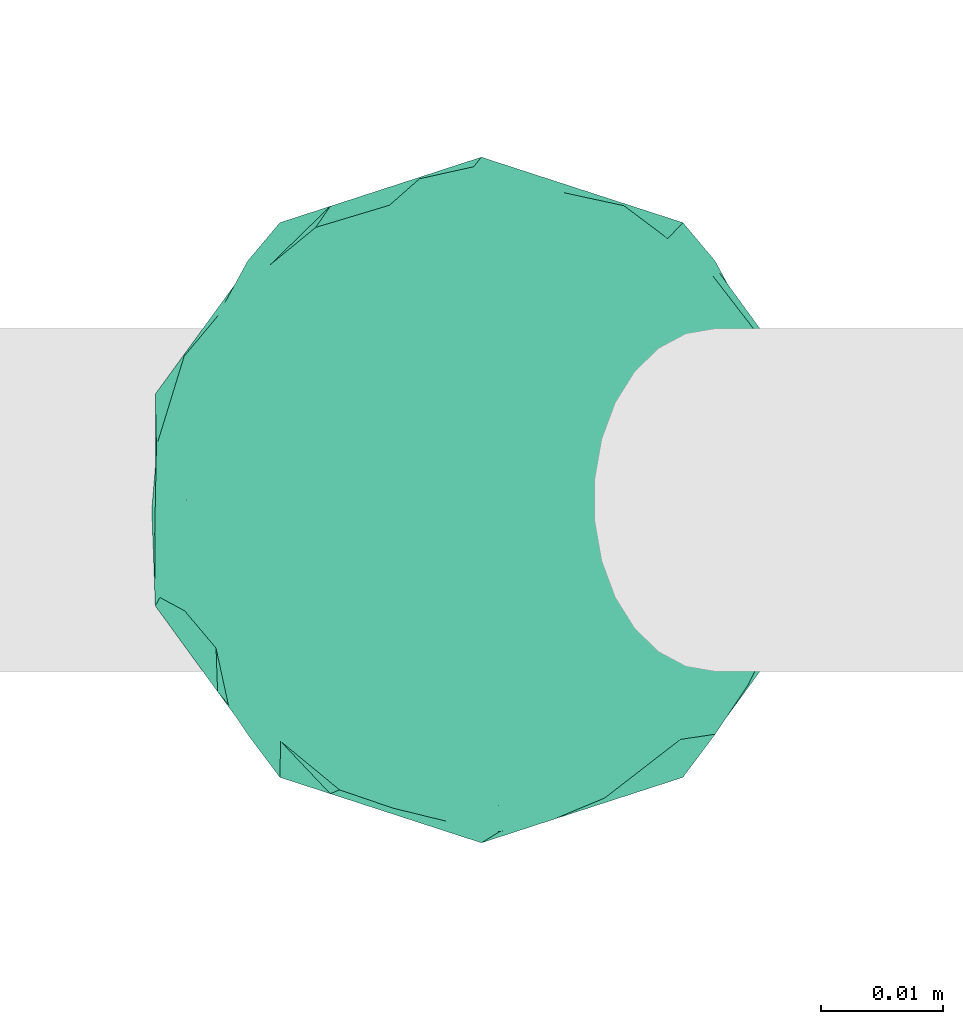
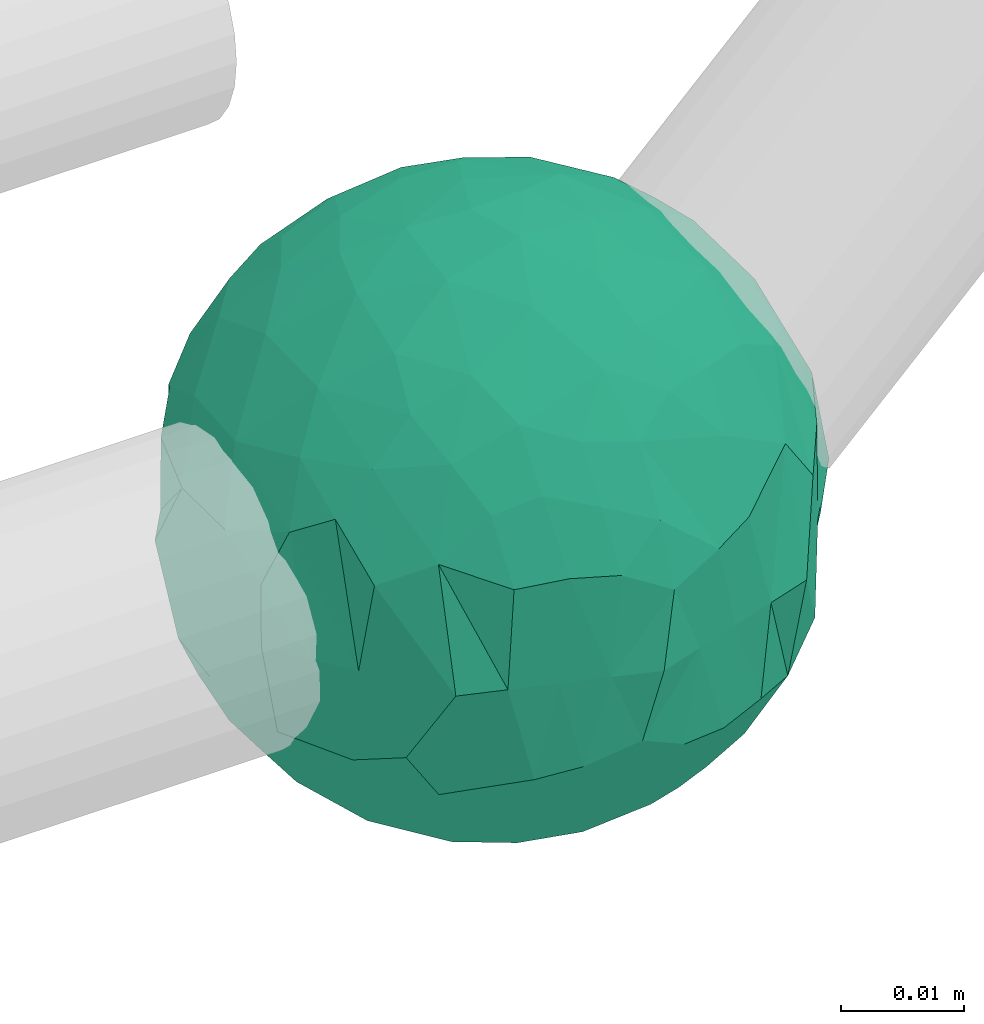
# One storey, part 324 of 331: 1 flow fitting.
"""IFC2X3 building model written with IfcOpenShell, lengths in millimetres."""

import ifcopenshell
import ifcopenshell.guid

model = None  # the IFC model being written
_history = None  # IfcOwnerHistory: only IFC2X3 demands one
_inside = {}  # id of a spatial element -> (the spatial element, [elements in it])
_under = {}  # id of a project, library or spatial element -> (it, [spatial elements below it])
_declared = {}  # id of a project -> (the project, [libraries it declares])
_typed = {}  # id of a type object -> (the type object, [elements of that type])
_made_of = {}  # id of a material, layer set ... -> (it, [elements and type objects made of it])


def new_model(schema):
    """Start an empty IFC model of exactly this schema.

    Asked for "IFC4X3", IfcOpenShell would pick the latest addendum, in which some entities
    have other attributes; the version numbers below select the first issue.
    IFC2X3 requires an IfcOwnerHistory on every rooted entity: one is made here for all.
    """
    global model, _history
    if schema == "IFC4X3":
        model = ifcopenshell.file(schema_version=(4, 3, 0, 0))
    else:
        model = ifcopenshell.file(schema=schema)
    _inside.clear()
    _under.clear()
    _declared.clear()
    _typed.clear()
    _made_of.clear()
    _history = None
    if model.schema == "IFC2X3":
        org = make("IfcOrganization", Name="unknown")
        user = make(
            "IfcPersonAndOrganization",
            ThePerson=make("IfcPerson", FamilyName="unknown"),
            TheOrganization=org,
        )
        app = make(
            "IfcApplication",
            ApplicationDeveloper=org,
            Version="unknown",
            ApplicationFullName="unknown",
            ApplicationIdentifier="unknown",
        )
        _history = make(
            "IfcOwnerHistory",
            OwningUser=user,
            OwningApplication=app,
            ChangeAction="ADDED",
            CreationDate=0,
        )
    return model


def make(cls, **values):
    """One entity of the class cls with the attributes given. An attribute that is None is left unset."""
    return model.create_entity(
        cls, **{name: value for name, value in values.items() if value is not None}
    )


def entity(cls, *values):
    """Any entity or typed value of the class cls, its attributes in the order of the schema. None: left unset."""
    e = model.create_entity(cls)
    for i, value in enumerate(values):
        if value is not None:
            e[i] = value
    return e


def rooted(cls, **values):
    """An entity with a GlobalId (a new one), such as an element, a storey or a relation."""
    return make(cls, GlobalId=ifcopenshell.guid.new(), OwnerHistory=_history, **values)


def si_unit(unit_type, name, prefix=None):
    """IfcSIUnit, for example si_unit("LENGTHUNIT", "METRE", prefix="MILLI")."""
    return make("IfcSIUnit", UnitType=unit_type, Prefix=prefix, Name=name)


def converted_unit(unit_type, name, factor, base, dimensions=None, offset=None):
    """IfcConversionBasedUnit, such as the inch: factor (a typed value) times the base unit."""
    return make(
        "IfcConversionBasedUnit"
        if offset is None
        else "IfcConversionBasedUnitWithOffset",
        ConversionOffset=offset,
        Dimensions=None
        if dimensions is None
        else entity("IfcDimensionalExponents", *dimensions),
        UnitType=unit_type,
        Name=name,
        ConversionFactor=make(
            "IfcMeasureWithUnit", ValueComponent=factor, UnitComponent=base
        ),
    )


def derived_unit(unit_type, elements):
    """IfcDerivedUnit: a product of units, each with its exponent."""
    return make(
        "IfcDerivedUnit",
        Elements=[
            make("IfcDerivedUnitElement", Unit=unit, Exponent=power)
            for unit, power in elements
        ],
        UnitType=unit_type,
    )


def assignment(units):
    """IfcUnitAssignment: the units of a project."""
    return None if units is None else make("IfcUnitAssignment", Units=units)


def point(xyz):
    """IfcCartesianPoint."""
    return None if xyz is None else make("IfcCartesianPoint", Coordinates=xyz)


def direction(xyz):
    """IfcDirection."""
    return None if xyz is None else make("IfcDirection", DirectionRatios=xyz)


def frame(location, z_axis=None, x_axis=None):
    """IfcAxis2Placement3D, a coordinate frame: its origin and axes. An axis left out is left unset."""
    return make(
        "IfcAxis2Placement3D",
        Location=point(location),
        Axis=direction(z_axis),
        RefDirection=direction(x_axis),
    )


def origin():
    """The frame at (0, 0, 0) with its axes left unset."""
    return frame((0.0, 0.0, 0.0))


def place(relative_to, where):
    """IfcLocalPlacement: puts the frame where relative to a parent placement (None: the world)."""
    return make(
        "IfcLocalPlacement", PlacementRelTo=relative_to, RelativePlacement=where
    )


def context(
    kind, dimensions, precision=None, world=None, true_north=None, identifier=None
):
    """IfcGeometricRepresentationContext, for example the 3D "Model" context."""
    return make(
        "IfcGeometricRepresentationContext",
        ContextIdentifier=identifier,
        ContextType=kind,
        CoordinateSpaceDimension=dimensions,
        Precision=precision,
        WorldCoordinateSystem=world,
        TrueNorth=true_north,
    )


def subcontext(parent, identifier, kind, view, scale=None):
    """IfcGeometricRepresentationSubContext, for example "Body" below "Model"."""
    return make(
        "IfcGeometricRepresentationSubContext",
        ContextIdentifier=identifier,
        ContextType=kind,
        ParentContext=parent,
        TargetScale=scale,
        TargetView=view,
    )


def project(units=None, contexts=None):
    """IfcProject with its units and contexts."""
    return rooted(
        "IfcProject",
        Name="project",
        RepresentationContexts=contexts,
        UnitsInContext=assignment(units),
    )


def spatial(cls, under=None, at=None, **own):
    """A site, building, storey or space (cls), placed at a placement, below another one or the project."""
    s = rooted(cls, ObjectPlacement=at, **own)
    if under is not None:
        _under.setdefault(under.id(), (under, []))[1].append(s)
    return s


def faces_of(points, faces, orient=None, outer=None):
    """IfcFace entities. A face is a list of loops; a loop is a list of indices into points, from 0.

    orient and outer hold one flag for each loop. By default every Orientation is true, the
    first loop of a face is its IfcFaceOuterBound and the others are IfcFaceBound.
    """
    made = []
    for i, loops in enumerate(faces):
        bounds = []
        for j, loop in enumerate(loops):
            is_outer = j == 0 if outer is None else outer[i][j]
            bounds.append(
                make(
                    "IfcFaceOuterBound" if is_outer else "IfcFaceBound",
                    Bound=make("IfcPolyLoop", Polygon=[points[k] for k in loop]),
                    Orientation=True if orient is None else orient[i][j],
                )
            )
        made.append(make("IfcFace", Bounds=bounds))
    return made


def faceted_brep(points, faces, orient=None, outer=None, voids=None):
    """IfcFacetedBrep: a solid bounded by flat faces; with voids (closed shells), ...WithVoids."""
    shared = [point(p) for p in points]
    hull = make("IfcClosedShell", CfsFaces=faces_of(shared, faces, orient, outer))
    if voids is None:
        return make("IfcFacetedBrep", Outer=hull)
    return make(
        "IfcFacetedBrepWithVoids",
        Outer=hull,
        Voids=[
            make(cls, CfsFaces=faces_of(shared, fs, o, b)) for cls, fs, o, b in voids
        ],
    )


def shape(context_of_items, identifier, shape_type, items):
    """IfcShapeRepresentation: the items that make up one representation, for example the "Body"."""
    return make(
        "IfcShapeRepresentation",
        ContextOfItems=context_of_items,
        RepresentationIdentifier=identifier,
        RepresentationType=shape_type,
        Items=items,
    )


def source(mapping_origin, context_of_items, identifier, shape_type, items):
    """IfcRepresentationMap: a shape defined once, which mapped items show again and again."""
    return make(
        "IfcRepresentationMap",
        MappingOrigin=mapping_origin,
        MappedRepresentation=shape(context_of_items, identifier, shape_type, items),
    )


def transform(
    local_origin,
    x_axis=None,
    y_axis=None,
    z_axis=None,
    scale=None,
    scale2=None,
    scale3=None,
    uniform=True,
):
    """IfcCartesianTransformationOperator3D, or its non-uniform kind. x_axis, y_axis, z_axis: its Axis1, 2, 3."""
    if uniform:
        return make(
            "IfcCartesianTransformationOperator3D",
            Axis1=direction(x_axis),
            Axis2=direction(y_axis),
            LocalOrigin=point(local_origin),
            Scale=scale,
            Axis3=direction(z_axis),
        )
    return make(
        "IfcCartesianTransformationOperator3DnonUniform",
        Axis1=direction(x_axis),
        Axis2=direction(y_axis),
        LocalOrigin=point(local_origin),
        Scale=scale,
        Axis3=direction(z_axis),
        Scale2=scale2,
        Scale3=scale3,
    )


def mapped(mapping_source, mapping_target):
    """IfcMappedItem: shows the shape of a source again, moved by a transform."""
    return make(
        "IfcMappedItem", MappingSource=mapping_source, MappingTarget=mapping_target
    )


def material(Name=None, Category=None):
    """IfcMaterial."""
    return make("IfcMaterial", Name=Name, Category=Category)


def material_list(materials):
    """IfcMaterialList."""
    return make("IfcMaterialList", Materials=materials)


def made_of(thing, what):
    """Note that an element or type object is made of a material, layer set ...; save() writes the relation."""
    if what is not None:
        _made_of.setdefault(what.id(), (what, []))[1].append(thing)
    return thing


def type_object(cls, material=None, **own):
    """A type object (cls), such as IfcWallType, which elements share."""
    return made_of(rooted(cls, **own), material)


def type_shapes(of_type, sources):
    """Give a type object the sources (RepresentationMaps) that its elements show as mapped items."""
    of_type.RepresentationMaps = sources


def element(
    cls,
    number,
    at=None,
    inside=None,
    cuts=None,
    type_object=None,
    material=None,
    context=None,
    identifier="Body",
    shape_type=None,
    held_by="IfcProductDefinitionShape",
    body=None,
    shapes=None,
    **own,
):
    """One element of the class cls, such as IfcWall. Its Tag is "e" and its number.

    at: its placement. inside: the storey or other place that contains it. cuts: it is an
    opening in that element (IfcRelVoidsElement). A single representation is given by context,
    identifier, shape_type and body (its items); several are given by shapes. held_by: the class
    of the entity that holds the representations. save() writes the other relations.
    """
    e = rooted(cls, Tag="e%d" % number, ObjectPlacement=at, **own)
    if body is not None:
        shapes = [shape(context, identifier, shape_type, body)]
    if shapes is not None:
        e.Representation = make(held_by, Representations=shapes)
    if inside is not None:
        _inside.setdefault(inside.id(), (inside, []))[1].append(e)
    if cuts is not None:
        rooted(
            "IfcRelVoidsElement", RelatingBuildingElement=cuts, RelatedOpeningElement=e
        )
    if type_object is not None:
        _typed.setdefault(type_object.id(), (type_object, []))[1].append(e)
    return made_of(e, material)


def aggregate(whole, parts):
    """IfcRelAggregates: a whole, such as a stair, and the parts it consists of."""
    return rooted("IfcRelAggregates", RelatingObject=whole, RelatedObjects=parts)


def save(model, path):
    """Write the relations noted so far, then the file.

    IfcRelAggregates (storeys below a building ...), IfcRelContainedInSpatialStructure (elements
    in a storey), IfcRelDefinesByType, IfcRelAssociatesMaterial and IfcRelDeclares: one each for
    every whole, place, type object, material and project.
    """
    for whole, parts in _under.values():
        aggregate(whole, parts)
    for where, things in _inside.values():
        rooted(
            "IfcRelContainedInSpatialStructure",
            RelatedElements=things,
            RelatingStructure=where,
        )
    for kind, things in _typed.values():
        rooted("IfcRelDefinesByType", RelatedObjects=things, RelatingType=kind)
    for what, things in _made_of.values():
        rooted("IfcRelAssociatesMaterial", RelatedObjects=things, RelatingMaterial=what)
    for by, libraries in _declared.values():
        rooted("IfcRelDeclares", RelatingContext=by, RelatedDefinitions=libraries)
    model.write(path)


model = new_model("IFC2X3")

# Units and contexts
model_context = context("Model", 3, precision=0.01, world=origin(), true_north=direction((6.12303176911189e-17, 1.0)))
body_context = subcontext(model_context, "Body", "Model", "MODEL_VIEW")
ifc_project = project(units=[si_unit("LENGTHUNIT", "METRE", prefix="MILLI"), si_unit("AREAUNIT", "SQUARE_METRE"), si_unit("VOLUMEUNIT", "CUBIC_METRE"), converted_unit("PLANEANGLEUNIT", "DEGREE", entity("IfcRatioMeasure", 0.0174532925199433), si_unit("PLANEANGLEUNIT", "RADIAN"), dimensions=[0, 0, 0, 0, 0, 0, 0]), si_unit("MASSUNIT", "GRAM", prefix="KILO"), derived_unit("MASSDENSITYUNIT", [(si_unit("MASSUNIT", "GRAM", prefix="KILO"), 1), (si_unit("LENGTHUNIT", "METRE"), -3)]), derived_unit("MOMENTOFINERTIAUNIT", [(si_unit("LENGTHUNIT", "METRE"), 4)]), si_unit("TIMEUNIT", "SECOND"), si_unit("FREQUENCYUNIT", "HERTZ"), si_unit("THERMODYNAMICTEMPERATUREUNIT", "DEGREE_CELSIUS"), derived_unit("THERMALTRANSMITTANCEUNIT", [(si_unit("MASSUNIT", "GRAM", prefix="KILO"), 1), (si_unit("THERMODYNAMICTEMPERATUREUNIT", "KELVIN"), -1), (si_unit("TIMEUNIT", "SECOND"), -3)]), derived_unit("VOLUMETRICFLOWRATEUNIT", [(si_unit("LENGTHUNIT", "METRE"), 3), (si_unit("TIMEUNIT", "SECOND"), -1)]), derived_unit("MASSFLOWRATEUNIT", [(si_unit("MASSUNIT", "GRAM", prefix="KILO"), 1), (si_unit("TIMEUNIT", "SECOND"), -1)]), derived_unit("ROTATIONALFREQUENCYUNIT", [(si_unit("TIMEUNIT", "SECOND"), -1)]), si_unit("ELECTRICCURRENTUNIT", "AMPERE"), si_unit("ELECTRICVOLTAGEUNIT", "VOLT"), si_unit("POWERUNIT", "WATT"), si_unit("FORCEUNIT", "NEWTON", prefix="KILO"), si_unit("ILLUMINANCEUNIT", "LUX"), si_unit("LUMINOUSFLUXUNIT", "LUMEN"), si_unit("LUMINOUSINTENSITYUNIT", "CANDELA"), derived_unit("USERDEFINED", [(si_unit("MASSUNIT", "GRAM", prefix="KILO"), -1), (si_unit("LENGTHUNIT", "METRE"), -2), (si_unit("TIMEUNIT", "SECOND"), 3), (si_unit("LUMINOUSFLUXUNIT", "LUMEN"), 1)]), derived_unit("LINEARVELOCITYUNIT", [(si_unit("LENGTHUNIT", "METRE"), 1), (si_unit("TIMEUNIT", "SECOND"), -1)]), si_unit("PRESSUREUNIT", "PASCAL"), derived_unit("USERDEFINED", [(si_unit("LENGTHUNIT", "METRE"), -2), (si_unit("MASSUNIT", "GRAM", prefix="KILO"), 1), (si_unit("TIMEUNIT", "SECOND"), -2)]), derived_unit("LINEARFORCEUNIT", [(si_unit("MASSUNIT", "GRAM", prefix="KILO"), 1), (si_unit("LENGTHUNIT", "METRE"), 1), (si_unit("TIMEUNIT", "SECOND"), -2), (si_unit("LENGTHUNIT", "METRE"), -1)]), derived_unit("PLANARFORCEUNIT", [(si_unit("MASSUNIT", "GRAM", prefix="KILO"), 1), (si_unit("LENGTHUNIT", "METRE"), 1), (si_unit("TIMEUNIT", "SECOND"), -2), (si_unit("LENGTHUNIT", "METRE"), -2)])], contexts=[model_context])

# Site, building, storey
site_placement = place(None, frame((0.0, -0.00077364408347762, 0.0)))
site = spatial("IfcSite", under=ifc_project, at=site_placement, CompositionType="ELEMENT")
building_placement = place(site_placement, origin())
building = spatial("IfcBuilding", under=site, at=building_placement, CompositionType="ELEMENT")
storey_placement = place(building_placement, origin())
storey = spatial("IfcBuildingStorey", under=building, at=storey_placement, CompositionType="ELEMENT", Elevation=0.0)

# Flow fitting
ifc_material_1 = material()
ifc_material_2 = material()
ifc_material_list = material_list([ifc_material_2, ifc_material_1])
pipe_fitting_type = type_object("IfcPipeFittingType", PredefinedType="NOTDEFINED", material=ifc_material_list)
shared_shape = source(origin(), body_context, "Body", "Brep", [
    faceted_brep([(-24.1075588827362, 0.0, -14.2416854590726), (-18.7208301437317, -4.33869147353172, -20.3643383154675), (-23.1457049670627, -8.26128283395463, -13.4174344609808), (-1.32611930987297, -24.9133350805053, -12.7109064484819), (-3.41680868783325, -20.8348062128393, -18.3912008434429), (3.23329059313737, -22.2520296444877, -16.6851133841187), (-26.6295824562568, 0.0, 0.0), (-26.6295824562569, 8.65247584251057, 0.0), (-26.6764557518501, 2.73453673071394, -8.0553719583706), (-8.22899353208365, 25.3262379212611, 0.0), (-7.22434699988445, 25.1625120542844, -9.93261282561769), (-11.5830155478856, 23.6719093720229, -9.45909390483378), (-7.51440969451584, 17.4158182850067, -20.5966725566745), (-3.28991586854822, 20.1970088154946, -19.1117055357464), (0.971293836224626, 16.4575742604896, -22.6319428627892), (-6.78628333874323, 4.37890610026463, -26.8099149534543), (-0.803050822013708, -2.04895266993681, -27.9133821371342), (-6.14662967993585, -3.29739371414127, -27.1172664232891), (-20.6672021889257, 16.7107688786072, -8.81004864730579), (-18.4213543431928, 12.4857851209013, -16.992906581196), (-21.6696260897231, 12.0961613259742, -12.9657312291894), (19.0008859122067, -19.1524758424963, 0.0), (18.9245250569434, -18.2683659163203, -9.59839351748567), (22.5164332922699, -13.6077270145562, -9.5833186992902), (20.2557342996506, -2.27041254255271, -19.1976679539174), (24.6522697565677, 0.0, -13.2765054080423), (23.3253615534156, -7.39957570201588, -13.6078575768853), (-26.5369130539378, -4.38016503326569, -7.78501122983919), (10.0745840960031, 24.3342419544525, -9.50512618513282), (12.3434902981411, 23.9893568818875, 0.0), (16.2606610871424, 19.5495421574165, -11.7220434415277), (26.6295824562694, 8.65247584251057, 0.0), (26.9141443887083, 0.794155670405175, -7.68102523074259), (25.0716619077246, 8.57841097406855, -9.04558645667729), (-21.5437847602151, -15.6524758424955, 0.0), (-24.2740580994413, -11.7420176682643, -7.54288568537562), (-21.5626341016361, -14.9856586638725, -9.72022865000511), (-5.54534056662308, -15.9755299995074, -22.3166224871674), (-10.2843228719923, -19.8131660152178, -16.9018092379968), (-11.0617566161225, -15.0153765515747, -20.884827209718), (-18.7934957394981, 4.28049890203109, -20.3096491116683), (8.22899353209607, -25.3262379212443, 0.0), (6.8524509794799, -25.07237444898, -10.412490339187), (11.6429616281817, -24.0335289385651, -8.41611141107421), (-14.337367759028, -17.7555578552008, -16.2228250003686), (-13.5332707512522, -22.2611307186633, -10.261220292898), (-17.2180006199453, -19.2374805342627, -10.8378871254929), (14.4748851935967, 0.0, -23.9682644059278), (21.3269099914595, 5.18551325980916, -17.3860105386183), (-2.05315667083673, 10.2441299852779, -25.9777279324034), (-9.19119322601112, 12.6829190757699, -23.2091691104999), (-8.22899353208354, -25.3262379212443, 0.0), (-5.04915435078711, -26.2358007428784, -8.37787560909308), (-4.11449676603864, -26.663118960618, 0.0), (-21.5437847602152, 15.6524758425122, 0.0), (-19.0008859121944, 19.152475842513, 0.0), (-16.4579870641736, 22.6524758425138, 0.0), (5.83215214474142, 18.6242521955768, -20.0779289648261), (9.76669698602029, 21.0366297388693, -15.686677124666), (10.5961135739233, 16.8397966785397, -19.7013609924404), (-3.33393851399284, 23.5796515851586, -14.7270120903003), (-7.7150081160596, 21.5710558408997, -16.0987018010227), (-13.3716791735882, 16.5489823743175, -18.2024552863984), (-14.5209153067055, 11.9891639601799, -20.7220405894667), (15.6895773293116, -7.38069781523379, -21.985505747831), (21.5437847602277, 15.6524758425122, 0.0), (21.77428226684, 15.099301926994, -9.04940401805642), (8.22899353209618, 25.3262379212611, 0.0), (6.38213192252836, 25.876325746251, -8.58394769310124), (8.02173608773004, 2.35316938312282, -26.7229179543212), (9.32530168136346, -5.19010954761892, -25.8863190012679), (16.4579870641859, -22.6524758424971, 0.0), (-2.9475403957684, 26.2108121682129, -9.39709162977656), (1.49183517514785, 27.0797238641763, -6.96153598357816), (-4.11449676603869, 26.6631189606348, 0.0), (14.93285149604, -16.7813182764077, -16.7151818148379), (19.4576366707445, -12.2727341207954, -15.9618411340816), (1.59120680932188, 21.292702895483, -18.1132234650574), (1.38949781008475, 24.9664395543026, -12.5994520443394), (-13.31344651068, 7.20825307994683, -23.5540491114106), (-12.7117353068981, 0.0, -24.9481820076593), (4.81129593186521, 8.90237267699796, -26.1074547242002), (9.52498445739671, 7.21945157210541, -25.32102269034), (5.70901308743605, 14.0121231914459, -23.5598720971831), (15.9260925167572, 7.32520373937486, -21.8334827117605), (-0.626647368203348, -27.2173968519503, -6.54374676152192), (-18.4213543432394, -12.4857851207328, -16.992906581257), (-7.50692771756147, -24.0729295652616, -12.1712817069037), (-8.19468641737628, -10.4432967412462, -24.6532891861301), (-1.92155439440709, -11.8750379533706, -25.2842065787166), (-11.1466562707475, -5.46490999603666, -25.0975459500902), (-14.135484715974, -9.78090899820782, -22.1025313259134), (3.8535961075247, -12.0601414621309, -24.9740422229442), (1.36199571548744, -7.07527396908649, -27.0570779267341), (10.7240485129656, -12.2899763248687, -22.7585426911685), (7.03411423013353, -16.6817738627625, -21.3597672690733), (15.2169469646691, -21.3474040758117, -9.83528669121213), (-16.3947159286249, 19.7091534796161, -11.2588879884648), (-12.3434902981286, 23.9893568818875, 0.0), (-11.8850743142173, 20.4512790211818, -14.9829968612275), (-24.2278354820837, 9.05652487504853, -10.7234017476081), (-26.2527755978532, 7.96087493871056, -5.6050195020892), (-21.9611132695247, 6.83761234611731, -15.9673592483927), (-26.6295824562568, -8.65247584249395, 0.0), (-24.0866836082359, -12.1524758424947, 0.0), (-24.086683608236, 12.1524758425114, 0.0), (-16.4579870641734, -22.6524758424971, 0.0), (-19.0008859121942, -19.1524758424963, 0.0), (-19.0823096342578, -19.5232158511765, -6.2216960589648), (-12.3434902981285, -23.9893568818707, 0.0), (0.745337186355852, 3.2669052476786, -27.7987734006645), (4.61840400024303, -2.73895864728468, -27.4803284190549), (15.7813970596494, -12.2918133705205, -19.592315608678), (19.6134249817277, -7.39957541014384, -18.5623232445706), (26.4171087788972, -5.23076909945076, -7.66651279216398), (22.602355744363, 10.2674437616644, -12.9504097775641), (26.6295824562694, 0.0, 0.0), (19.4576366704536, 12.2727341209255, -15.9618411343492), (19.0008859122069, 19.152475842513, 0.0), (19.0905418175867, 19.1300526549401, -7.32067609792848), (24.0866836082486, 12.1524758425114, 0.0), (15.1758820564139, 14.2314970585574, -18.7391860891178), (10.660674573336, 11.9288483234161, -22.979395016379), (24.0866836082485, -12.1524758424947, 0.0), (26.6295824562693, -8.65247584249395, 0.0), (21.5437847602276, -15.6524758424955, 0.0), (12.343490298141, -23.9893568818707, 0.0), (9.26650693992487, -21.3180125792932, -15.6100669057258), (4.11449676605117, -26.663118960618, 0.0), (0.971293834743383, -16.4575742594414, -22.6319428636028), (0.0, -28.0, 0.0), (4.11449676605122, 26.6631189606348, 0.0), (0.0, 28.0, 0.0), (16.4579870641861, 22.6524758425138, 0.0), (24.1075586963495, 0.0, 14.2416857745954), (18.7208297526088, -4.33869145666241, 20.3643386786266), (23.1457047918582, -8.26128287505996, 13.4174347379257), (1.32611902532217, -24.9133350021468, 12.7109066317488), (3.41680918419379, -20.8348058874746, 18.3912011198204), (-3.2332908194052, -22.2520290591321, 16.6851141209226), (26.6764556913252, 2.73453683006845, 8.05537212511708), (7.22434669061077, 25.1625120151201, 9.93261314978463), (11.5830154326477, 23.6719093141135, 9.45909419088002), (7.51440935996004, 17.4158179872223, 20.5966729305293), (3.2899152198879, 20.19700829361, 19.1117061989272), (-0.97129491275952, 16.4575741495153, 22.631942897282), (6.78628181199584, 4.37890613600364, 26.8099153340756), (0.803049678607695, -2.04895321118, 27.9133821302965), (6.14662891800778, -3.29739346425557, 27.1172666263788), (20.6672021612941, 16.7107687688383, 8.81004892035944), (18.4213540037245, 12.4857851243545, 16.9929069466731), (21.6696259598481, 12.0961611242155, 12.9657316344942), (-18.9245264651495, -18.2683651067826, 9.59839228176072), (-22.5164345244777, -13.6077254796464, 9.58331798360789), (-20.2557359344147, -2.27041120971219, 19.1976663866657), (-24.6522711015508, 0.0, 13.2765029106044), (-23.3253623760355, -7.39957445459627, 13.6078568451114), (26.5369130028701, -4.38016502392315, 7.78501140921041), (-10.0745844058051, 24.334241934429, 9.50512590801583), (-16.2606620059772, 19.5495422485866, 11.7220420148615), (-26.9141451149613, 0.794153897896192, 7.68102286918285), (-25.0716635209938, 8.57840990116444, 9.04558300262995), (24.2740580577137, -11.7420176588426, 7.54288583436411), (21.5626339432896, -14.9856587784331, 9.72022882467519), (5.54533930645119, -15.9755293953014, 22.3166232328259), (10.2843222724574, -19.8131657220565, 16.9018099464611), (11.0617555293724, -15.0153762565878, 20.8848279974078), (18.7934953241618, 4.28049890690814, 20.3096494949789), (-6.85245009383224, -25.0723746439623, 10.4124904525185), (-11.6429617226824, -24.0335280703182, 8.41611375973467), (14.337367403302, -17.7555573589115, 16.2228258579373), (13.53326991983, -22.2611307894103, 10.2612212359713), (17.2180003254061, -19.2374806397769, 10.8378874061495), (-14.47488678898, 0.0, 23.9682634424345), (-21.3269121707349, 5.18551348028213, 17.3860077995878), (2.05315411339286, 10.2441293058615, 25.9777284024518), (9.19119234669881, 12.6829185848092, 23.2091697270137), (5.04915405856798, -26.2358007552035, 8.37787574661381), (-5.83215314955032, 18.6242520567439, 20.0779288017273), (-9.76669769074009, 21.0366296772331, 15.6866767685454), (-10.5961147601494, 16.8397965420699, 19.7013604710821), (3.33393806690902, 23.5796513654291, 14.7270125433238), (7.71500780665026, 21.5710556420937, 16.0987022156888), (13.371679208674, 16.5489816205853, 18.2024559458944), (14.520915154062, 11.989163404725, 20.7220410178062), (-15.6895804640584, -7.38069820251719, 21.985503380746), (-21.7742825961245, 15.099302011231, 9.04940308515942), (-6.38213213122465, 25.8763257289409, 8.58394759010478), (-8.02173791427514, 2.3531683497192, 26.7229174970174), (-9.3253040963609, -5.19010994323736, 25.8863180519595), (2.94754014659674, 26.2108119089475, 9.3970924310884), (-1.49183517044238, 27.0797238768358, 6.96153593533578), (-14.9328527481035, -16.7813185930554, 16.7151803783655), (-19.4576379779698, -12.2727335956104, 15.9618399443464), (-1.59120763092257, 21.2927027827449, 18.1132235254041), (-1.38949818335658, 24.9664394822704, 12.5994521459044), (13.3134459519279, 7.20825293656125, 23.5540494711175), (12.7117346461245, 0.0, 24.9481823443429), (-4.81129838406353, 8.90237136370108, 26.1074547201035), (-9.52498760745335, 7.21945052377658, 25.3210218042738), (-5.70901464245565, 14.0121225459294, 23.5598721042827), (-15.926095080171, 7.32520283214134, 21.833481146285), (0.626647236531264, -27.2173968272822, 6.54374687673037), (18.4213540037315, -12.4857851243052, 16.9929069466893), (7.5069279840396, -24.072929863337, 12.1712809530035), (8.1946852015021, -10.4432964397171, 24.6532897180135), (1.92155260249205, -11.8750380639816, 25.2842066629462), (11.1466554944021, -5.46490972709787, 25.0975463534534), (14.1354840421536, -9.78090856440266, 22.1025319488231), (-3.85359819328695, -12.0601415803061, 24.9740418440292), (-1.36199712880475, -7.07527433256025, 27.0570777605399), (-10.7240500462686, -12.2899763883294, 22.7585419343816), (-7.03411576409744, -16.6817745901739, 21.359766195805), (-15.2169486195664, -21.3474037697252, 9.83528479512482), (16.3947158272081, 19.7091534742283, 11.2588881455898), (11.885074346892, 20.4512786335895, 14.9829973643652), (24.2278354743051, 9.05652481495055, 10.7234018159633), (26.2527755760936, 7.96087497699178, 5.60501954969064), (21.9611132159321, 6.8376119942177, 15.967359472808), (19.082309617878, -19.523215758984, 6.22169639853039), (-0.74533943333495, 3.26690434514674, 27.79877344648), (-4.61840598211705, -2.73895861962604, 27.4803280887277), (-15.7813984870387, -12.2918137578436, 19.5923142159189), (-19.6134280697398, -7.3995744435976, 18.5623203669789), (-26.4171093949137, -5.23076878498256, 7.66651088401789), (-22.6023574072546, 10.2674428215611, 12.9504076206326), (-19.4576379779691, 12.2727335955621, 15.9618399443973), (-19.0905420296178, 19.1300526550208, 7.32067554475561), (-15.1758834138466, 14.2314968698719, 18.7391851330879), (-10.6606760798075, 11.9288481498782, 22.9793944075676), (-9.26650760829329, -21.3180125287798, 15.6100665779392), (-0.971294912538462, -16.4575741493031, 22.6319428974336)], [[[0, 1, 2]], [[3, 4, 5]], [[6, 7, 8]], [[9, 10, 11]], [[12, 13, 14]], [[15, 16, 17]], [[18, 19, 20]], [[21, 22, 23]], [[24, 25, 26]], [[27, 8, 0]], [[28, 29, 30]], [[31, 32, 33]], [[34, 35, 36]], [[37, 38, 39]], [[0, 40, 1]], [[41, 42, 43]], [[44, 45, 46]], [[24, 47, 48]], [[49, 15, 50]], [[51, 52, 53]], [[18, 54, 55, 56]], [[57, 58, 59]], [[60, 13, 61]], [[48, 33, 25]], [[62, 63, 19]], [[64, 47, 24]], [[65, 33, 66]], [[67, 28, 68]], [[69, 47, 70]], [[21, 71, 22]], [[60, 10, 72]], [[73, 72, 74]], [[75, 76, 22]], [[77, 60, 78]], [[8, 27, 6]], [[62, 12, 50]], [[79, 40, 63]], [[50, 15, 79]], [[80, 15, 17]], [[69, 81, 82]], [[57, 77, 58]], [[30, 59, 58]], [[83, 81, 49]], [[47, 84, 48]], [[3, 42, 85]], [[37, 4, 38]], [[36, 86, 46]], [[87, 4, 3]], [[37, 88, 89]], [[90, 91, 1]], [[92, 89, 93]], [[94, 70, 64]], [[95, 92, 94]], [[47, 64, 70]], [[3, 5, 42]], [[96, 75, 22]], [[97, 56, 98]], [[98, 9, 11]], [[97, 99, 62]], [[19, 18, 97]], [[97, 18, 56]], [[100, 54, 20]], [[101, 8, 7]], [[102, 40, 0]], [[2, 86, 36]], [[103, 6, 27]], [[27, 0, 2]], [[104, 35, 34]], [[27, 35, 104]], [[86, 2, 1]], [[91, 44, 86]], [[40, 80, 1]], [[80, 40, 79]], [[19, 102, 20]], [[8, 100, 0]], [[101, 7, 105]], [[106, 107, 108]], [[107, 36, 108]], [[51, 45, 87]], [[38, 44, 39]], [[109, 106, 46]], [[80, 79, 15]], [[63, 62, 50]], [[80, 17, 90]], [[49, 110, 15]], [[88, 17, 89]], [[93, 17, 16]], [[110, 49, 81]], [[12, 14, 49]], [[110, 81, 69]], [[14, 57, 83]], [[111, 16, 110]], [[82, 84, 47]], [[16, 111, 93]], [[93, 70, 92]], [[75, 94, 112]], [[113, 24, 26]], [[64, 24, 113]], [[25, 24, 48]], [[26, 23, 76]], [[114, 26, 25]], [[33, 115, 66]], [[114, 32, 116]], [[84, 117, 48]], [[114, 25, 32]], [[118, 66, 119]], [[33, 65, 120, 31]], [[117, 84, 121]], [[81, 122, 82]], [[114, 123, 23]], [[114, 23, 26]], [[124, 114, 116]], [[22, 76, 23]], [[23, 123, 125, 21]], [[75, 112, 76]], [[43, 96, 126]], [[94, 75, 95]], [[71, 96, 22]], [[43, 126, 41]], [[124, 123, 114]], [[75, 96, 127]], [[126, 96, 71]], [[43, 127, 96]], [[127, 43, 42]], [[127, 42, 5]], [[127, 5, 95]], [[42, 128, 85]], [[42, 41, 128]], [[129, 5, 4]], [[129, 4, 37]], [[38, 4, 87]], [[45, 38, 87]], [[3, 52, 87]], [[129, 37, 89]], [[53, 85, 130]], [[39, 88, 37]], [[88, 39, 91]], [[46, 86, 44]], [[90, 17, 88]], [[91, 86, 1]], [[91, 39, 44]], [[109, 46, 45]], [[51, 109, 45]], [[45, 44, 38]], [[130, 85, 128]], [[3, 85, 52]], [[129, 89, 92]], [[17, 93, 89]], [[129, 92, 95]], [[94, 92, 70]], [[129, 95, 5]], [[127, 95, 75]], [[98, 11, 97]], [[61, 11, 10]], [[10, 60, 61]], [[77, 13, 60]], [[68, 78, 73]], [[10, 9, 74]], [[78, 60, 72]], [[14, 77, 57]], [[58, 77, 68]], [[131, 67, 68]], [[72, 10, 74]], [[73, 132, 131]], [[73, 78, 72]], [[132, 73, 74]], [[61, 13, 12]], [[13, 77, 14]], [[99, 11, 61]], [[49, 50, 12]], [[61, 12, 99]], [[97, 62, 19]], [[83, 49, 14]], [[59, 83, 57]], [[83, 122, 81]], [[122, 83, 59]], [[59, 121, 122]], [[30, 121, 59]], [[118, 65, 66]], [[29, 28, 67]], [[122, 121, 84]], [[117, 121, 30]], [[29, 133, 30]], [[104, 103, 27]], [[35, 2, 36]], [[2, 35, 27]], [[119, 66, 117]], [[119, 133, 118]], [[115, 117, 66]], [[119, 30, 133]], [[30, 119, 117]], [[115, 48, 117]], [[115, 33, 48]], [[116, 32, 31]], [[32, 25, 33]], [[131, 68, 73]], [[77, 78, 68]], [[28, 58, 68]], [[30, 58, 28]], [[105, 54, 100]], [[101, 100, 8]], [[101, 105, 100]], [[18, 20, 54]], [[100, 20, 102]], [[100, 102, 0]], [[40, 102, 19]], [[107, 34, 36]], [[108, 46, 106]], [[46, 108, 36]], [[111, 70, 93]], [[110, 16, 15]], [[111, 69, 70]], [[69, 111, 110]], [[69, 82, 47]], [[82, 122, 84]], [[64, 113, 112]], [[76, 113, 26]], [[76, 112, 113]], [[64, 112, 94]], [[87, 52, 51]], [[53, 52, 85]], [[80, 90, 1]], [[91, 90, 88]], [[11, 99, 97]], [[62, 99, 12]], [[19, 63, 40]], [[79, 63, 50]], [[134, 135, 136]], [[137, 138, 139]], [[116, 31, 140]], [[67, 141, 142]], [[143, 144, 145]], [[146, 147, 148]], [[149, 150, 151]], [[107, 152, 153]], [[154, 155, 156]], [[157, 134, 136]], [[158, 98, 159]], [[7, 160, 161]], [[125, 162, 163]], [[164, 165, 166]], [[134, 167, 135]], [[51, 168, 169]], [[170, 171, 172]], [[154, 173, 174]], [[175, 146, 176]], [[41, 177, 128]], [[149, 65, 118, 133]], [[178, 179, 180]], [[181, 144, 182]], [[174, 161, 155]], [[183, 184, 150]], [[185, 173, 154]], [[54, 161, 186]], [[187, 158, 179]], [[188, 173, 189]], [[107, 106, 152]], [[181, 141, 190]], [[191, 190, 131]], [[192, 193, 152]], [[194, 181, 195]], [[140, 157, 116]], [[183, 143, 176]], [[196, 167, 184]], [[176, 146, 196]], [[197, 146, 148]], [[188, 198, 199]], [[178, 194, 179]], [[159, 180, 179]], [[200, 198, 175]], [[173, 201, 174]], [[137, 168, 202]], [[164, 138, 165]], [[163, 203, 172]], [[204, 138, 137]], [[164, 205, 206]], [[207, 208, 135]], [[209, 206, 210]], [[211, 189, 185]], [[212, 209, 211]], [[173, 185, 189]], [[137, 139, 168]], [[213, 192, 152]], [[214, 133, 29]], [[29, 67, 142]], [[214, 215, 183]], [[150, 149, 214]], [[214, 149, 133]], [[216, 65, 151]], [[217, 140, 31]], [[218, 167, 134]], [[163, 136, 203]], [[116, 157, 124]], [[134, 157, 140]], [[123, 162, 125]], [[157, 162, 123]], [[203, 136, 135]], [[208, 170, 203]], [[167, 197, 135]], [[197, 167, 196]], [[150, 218, 151]], [[140, 216, 134]], [[217, 31, 120]], [[71, 21, 219]], [[21, 163, 219]], [[41, 171, 204]], [[165, 170, 166]], [[126, 71, 172]], [[197, 196, 146]], [[184, 183, 176]], [[197, 148, 207]], [[175, 220, 146]], [[205, 148, 206]], [[210, 148, 147]], [[220, 175, 198]], [[143, 145, 175]], [[220, 198, 188]], [[145, 178, 200]], [[221, 147, 220]], [[199, 201, 173]], [[147, 221, 210]], [[210, 189, 209]], [[192, 211, 222]], [[223, 154, 156]], [[185, 154, 223]], [[155, 154, 174]], [[156, 153, 193]], [[224, 156, 155]], [[161, 225, 186]], [[224, 160, 6]], [[201, 226, 174]], [[224, 155, 160]], [[55, 186, 227]], [[161, 54, 105, 7]], [[226, 201, 228]], [[198, 229, 199]], [[224, 104, 153]], [[224, 153, 156]], [[103, 224, 6]], [[152, 193, 153]], [[153, 104, 34, 107]], [[192, 222, 193]], [[169, 213, 109]], [[211, 192, 212]], [[106, 213, 152]], [[169, 109, 51]], [[103, 104, 224]], [[192, 213, 230]], [[109, 213, 106]], [[169, 230, 213]], [[230, 169, 168]], [[230, 168, 139]], [[230, 139, 212]], [[168, 53, 202]], [[168, 51, 53]], [[231, 139, 138]], [[231, 138, 164]], [[165, 138, 204]], [[171, 165, 204]], [[137, 177, 204]], [[231, 164, 206]], [[128, 202, 130]], [[166, 205, 164]], [[205, 166, 208]], [[172, 203, 170]], [[207, 148, 205]], [[208, 203, 135]], [[208, 166, 170]], [[126, 172, 171]], [[41, 126, 171]], [[171, 170, 165]], [[130, 202, 53]], [[137, 202, 177]], [[231, 206, 209]], [[148, 210, 206]], [[231, 209, 212]], [[211, 209, 189]], [[231, 212, 139]], [[230, 212, 192]], [[29, 142, 214]], [[182, 142, 141]], [[141, 181, 182]], [[194, 144, 181]], [[187, 195, 191]], [[141, 67, 131]], [[195, 181, 190]], [[145, 194, 178]], [[179, 194, 187]], [[74, 9, 187]], [[190, 141, 131]], [[191, 132, 74]], [[191, 195, 190]], [[132, 191, 131]], [[182, 144, 143]], [[144, 194, 145]], [[215, 142, 182]], [[175, 176, 143]], [[182, 143, 215]], [[214, 183, 150]], [[200, 175, 145]], [[180, 200, 178]], [[200, 229, 198]], [[229, 200, 180]], [[180, 228, 229]], [[159, 228, 180]], [[55, 54, 186]], [[158, 187, 9]], [[229, 228, 201]], [[226, 228, 159]], [[98, 56, 159]], [[123, 124, 157]], [[162, 136, 163]], [[136, 162, 157]], [[227, 186, 226]], [[227, 56, 55]], [[225, 226, 186]], [[227, 159, 56]], [[159, 227, 226]], [[225, 174, 226]], [[225, 161, 174]], [[6, 160, 7]], [[160, 155, 161]], [[74, 187, 191]], [[194, 195, 187]], [[179, 158, 159]], [[158, 9, 98]], [[120, 65, 216]], [[217, 216, 140]], [[217, 120, 216]], [[149, 151, 65]], [[216, 151, 218]], [[216, 218, 134]], [[167, 218, 150]], [[21, 125, 163]], [[219, 172, 71]], [[172, 219, 163]], [[221, 189, 210]], [[220, 147, 146]], [[221, 188, 189]], [[188, 221, 220]], [[188, 199, 173]], [[199, 229, 201]], [[185, 223, 222]], [[193, 223, 156]], [[193, 222, 223]], [[185, 222, 211]], [[204, 177, 41]], [[128, 177, 202]], [[197, 207, 135]], [[208, 207, 205]], [[142, 215, 214]], [[183, 215, 143]], [[150, 184, 167]], [[196, 184, 176]]]),
])
type_shapes(pipe_fitting_type, [shared_shape])
flow_fitting_placement = place(building_placement, frame((20287.2140827497, 9630.07284823333, 2950.0), z_axis=(0.0, 0.0, -1.0), x_axis=(1.0, 0.0, 0.0)))
element("IfcFlowFitting", 1, at=flow_fitting_placement, inside=storey, type_object=pipe_fitting_type, material=ifc_material_1, context=body_context, shape_type="MappedRepresentation", body=[
    mapped(shared_shape, transform((0.0, 0.0, 0.0), scale=1.0)),
])

save(model, "model.ifc")
